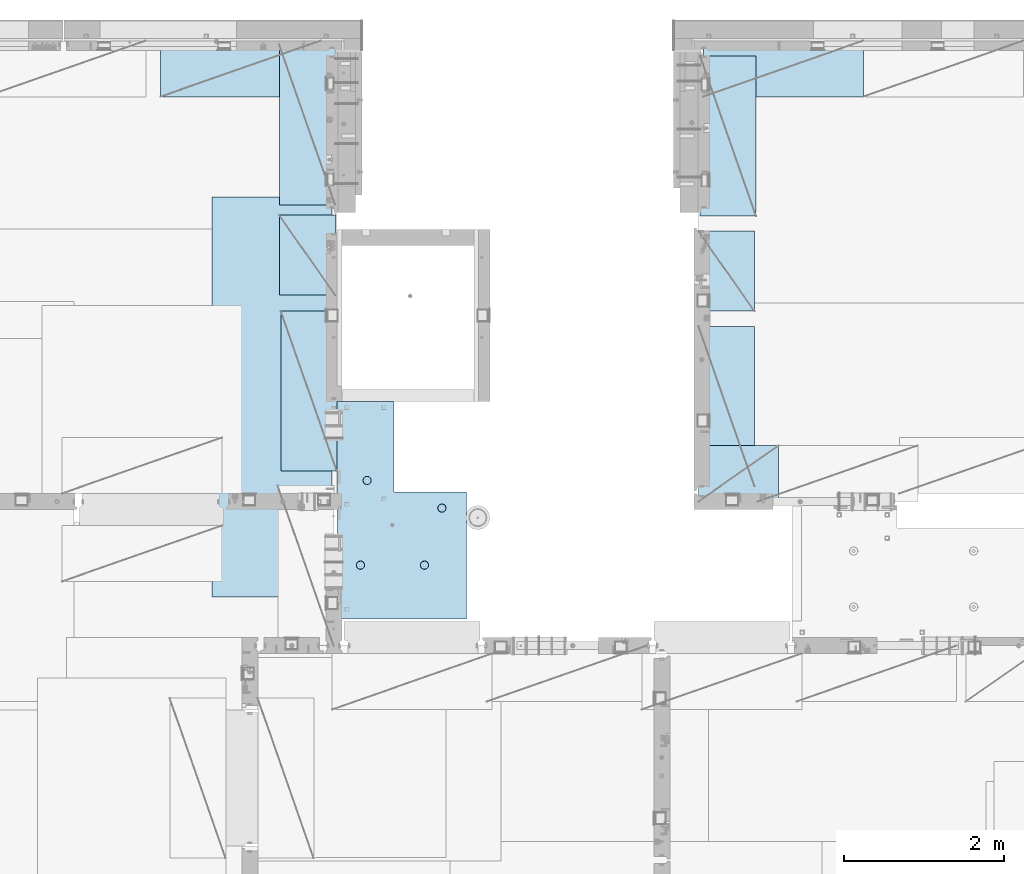
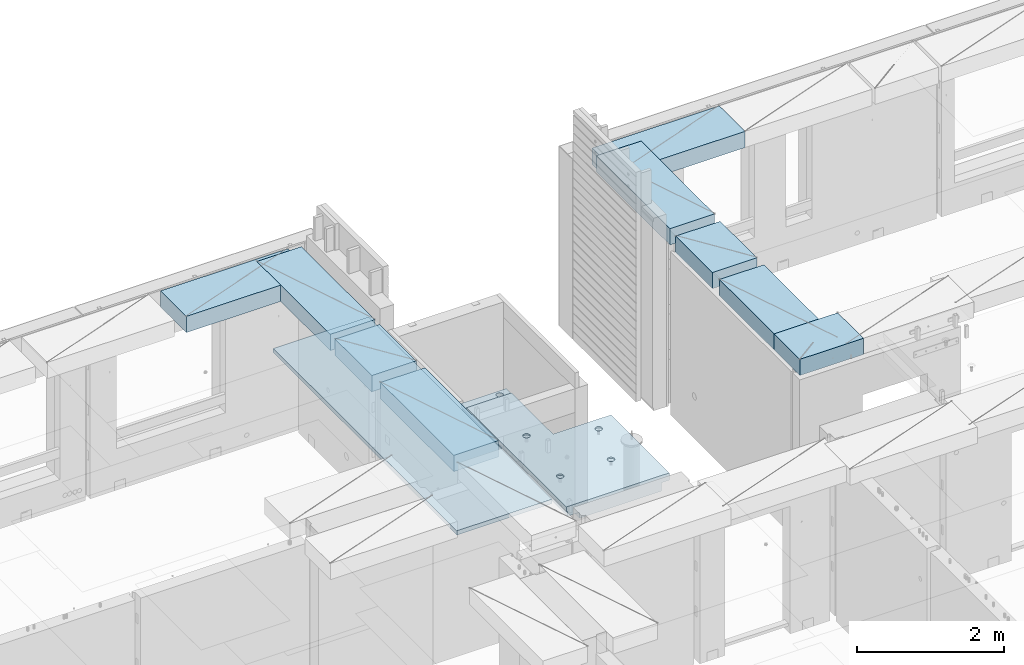
# One storey, part 177 of 309: 10 plates, 1 slab, 11 elements without a shape of their own.
"""IFC2X3 building model written with IfcOpenShell, lengths in millimetres."""

from ifc_helpers import new_model, si_unit, frame, origin_with_axes, place, context, subcontext, project, spatial, faceted_brep, material, type_object, element, aggregate, save


model = new_model("IFC2X3")

# Units and contexts
model_context = context("Model", 3, precision=1e-05, world=origin_with_axes())
body_context = subcontext(model_context, "Body", "Model", "MODEL_VIEW")
ifc_project = project(units=[si_unit("LENGTHUNIT", "METRE", prefix="MILLI"), si_unit("AREAUNIT", "SQUARE_METRE"), si_unit("VOLUMEUNIT", "CUBIC_METRE"), si_unit("MASSUNIT", "GRAM", prefix="KILO"), si_unit("TIMEUNIT", "SECOND"), si_unit("PLANEANGLEUNIT", "RADIAN"), si_unit("SOLIDANGLEUNIT", "STERADIAN"), si_unit("THERMODYNAMICTEMPERATUREUNIT", "DEGREE_CELSIUS"), si_unit("LUMINOUSINTENSITYUNIT", "LUMEN")], contexts=[model_context])

# Site, building, storey
site_placement = place(None, origin_with_axes())
site = spatial("IfcSite", under=ifc_project, at=site_placement, CompositionType="ELEMENT")
building_placement = place(site_placement, origin_with_axes())
building = spatial("IfcBuilding", under=site, at=building_placement, CompositionType="ELEMENT")
storey_placement = place(building_placement, origin_with_axes())
storey = spatial("IfcBuildingStorey", under=building, at=storey_placement, Name="7", CompositionType="ELEMENT", Elevation=0.0)

# Assembly, plate
assembly_1_placement = place(storey_placement, origin_with_axes())
assembly_1 = element("IfcElementAssembly", 1, at=assembly_1_placement, inside=storey, Name="Steel Assembly", AssemblyPlace="NOTDEFINED", PredefinedType="NOTDEFINED")
ifc_material_1 = material()
plate_type_1 = type_object("IfcPlateType", PredefinedType="NOTDEFINED")
plate_1_placement = place(assembly_1_placement, frame((17690.0000122641, 20790.0, 102695.100000381), z_axis=(0.0, -1.0, 0.0), x_axis=(-1.0, 3.00000001838171e-08, 0.0)))
plate_1 = element("IfcPlate", 2, at=plate_1_placement, type_object=plate_type_1, material=ifc_material_1, context=body_context, shape_type="Brep", body=[
    faceted_brep([(0.0, -35.0, 0.0), (0.0, -35.0, 5000.0), (0.0, 35.0, 5000.0), (0.0, 35.0, 0.0), (1499.99951171875, -35.0, 5000.0), (1499.99951171875, 35.0, 5000.0), (1500.0, -35.0, 0.0), (1500.0, 35.0, 0.0)], [[[0, 1, 2, 3]], [[1, 4, 5, 2]], [[4, 6, 7, 5]], [[6, 0, 3, 7]], [[5, 7, 3, 2]], [[6, 4, 1, 0]]]),
])
aggregate(assembly_1, [plate_1])

assembly_2_placement = place(storey_placement, origin_with_axes())
assembly_2 = element("IfcElementAssembly", 3, at=assembly_2_placement, inside=storey, Name="Steel Assembly", AssemblyPlace="NOTDEFINED", PredefinedType="NOTDEFINED")
plate_type_2 = type_object("IfcPlateType", PredefinedType="NOTDEFINED")
plate_2_placement = place(assembly_2_placement, frame((24330.0, 22740.0001220703, 102595.3), z_axis=(0.0, -1.0, 0.0), x_axis=(-1.0, 3.00000001838171e-08, 0.0)))
plate_2 = element("IfcPlate", 4, at=plate_2_placement, type_object=plate_type_2, material=ifc_material_1, Name="RE1", context=body_context, shape_type="Brep", body=[
    faceted_brep([(1.81898940354586e-12, -135.0, 1.81898940354586e-12), (0.0, -135.0, 699.999999999996), (0.0, 135.0, 699.999999999996), (1.81898940354586e-12, 135.0, 1.81898940354586e-12), (1999.99951171875, -135.0, 699.999999999993), (1999.99951171875, 135.0, 699.999999999993), (2000.0, -135.0, -3.63797880709171e-12), (2000.0, 135.0, -3.63797880709171e-12)], [[[0, 1, 2, 3]], [[1, 4, 5, 2]], [[4, 6, 7, 5]], [[6, 0, 3, 7]], [[5, 7, 3, 2]], [[6, 4, 1, 0]]]),
])
aggregate(assembly_2, [plate_2])

assembly_3_placement = place(storey_placement, origin_with_axes())
assembly_3 = element("IfcElementAssembly", 5, at=assembly_3_placement, inside=storey, Name="Steel Assembly", AssemblyPlace="NOTDEFINED", PredefinedType="NOTDEFINED")
plate_3_placement = place(assembly_3_placement, frame((17730.0001220703, 20690.0, 102595.3), z_axis=(-1.0, 3.00000001838171e-08, 0.0), x_axis=(0.0, 1.0, 0.0)))
plate_3 = element("IfcPlate", 6, at=plate_3_placement, type_object=plate_type_2, material=ifc_material_1, Name="RE1", context=body_context, shape_type="Brep", body=[
    faceted_brep([(1.81898940354586e-12, -135.0, 1.81898940354586e-12), (0.0, -135.0, 699.999999999996), (0.0, 135.0, 699.999999999996), (1.81898940354586e-12, 135.0, 1.81898940354586e-12), (1999.99951171875, -135.0, 699.999999999993), (1999.99951171875, 135.0, 699.999999999993), (2000.0, -135.0, -3.63797880709171e-12), (2000.0, 135.0, -3.63797880709171e-12)], [[[0, 1, 2, 3]], [[1, 4, 5, 2]], [[4, 6, 7, 5]], [[6, 0, 3, 7]], [[5, 7, 3, 2]], [[6, 4, 1, 0]]]),
])
aggregate(assembly_3, [plate_3])

assembly_4_placement = place(storey_placement, origin_with_axes())
assembly_4 = element("IfcElementAssembly", 7, at=assembly_4_placement, inside=storey, Name="Steel Assembly", AssemblyPlace="NOTDEFINED", PredefinedType="NOTDEFINED")
plate_4_placement = place(assembly_4_placement, frame((22269.9998779297, 19170.0, 102595.3), z_axis=(1.0, 0.0, 0.0), x_axis=(0.0, -1.0, 0.0)))
plate_4 = element("IfcPlate", 8, at=plate_4_placement, type_object=plate_type_2, material=ifc_material_1, Name="RE1", context=body_context, shape_type="Brep", body=[
    faceted_brep([(1.81898940354586e-12, -135.0, 1.81898940354586e-12), (0.0, -135.0, 699.999999999996), (0.0, 135.0, 699.999999999996), (1.81898940354586e-12, 135.0, 1.81898940354586e-12), (1999.99951171875, -135.0, 699.999999999993), (1999.99951171875, 135.0, 699.999999999993), (2000.0, -135.0, -3.63797880709171e-12), (2000.0, 135.0, -3.63797880709171e-12)], [[[0, 1, 2, 3]], [[1, 4, 5, 2]], [[4, 6, 7, 5]], [[6, 0, 3, 7]], [[5, 7, 3, 2]], [[6, 4, 1, 0]]]),
])
aggregate(assembly_4, [plate_4])

assembly_5_placement = place(storey_placement, origin_with_axes())
assembly_5 = element("IfcElementAssembly", 9, at=assembly_5_placement, inside=storey, Name="Steel Assembly", AssemblyPlace="NOTDEFINED", PredefinedType="NOTDEFINED")
plate_5_placement = place(assembly_5_placement, frame((22289.9998779297, 22550.0, 102595.3), z_axis=(1.0, 0.0, 0.0), x_axis=(0.0, -1.0, 0.0)))
plate_5 = element("IfcPlate", 10, at=plate_5_placement, type_object=plate_type_2, material=ifc_material_1, Name="RE1", context=body_context, shape_type="Brep", body=[
    faceted_brep([(1.81898940354586e-12, -135.0, 1.81898940354586e-12), (0.0, -135.0, 699.999999999996), (0.0, 135.0, 699.999999999996), (1.81898940354586e-12, 135.0, 1.81898940354586e-12), (1999.99951171875, -135.0, 699.999999999993), (1999.99951171875, 135.0, 699.999999999993), (2000.0, -135.0, -3.63797880709171e-12), (2000.0, 135.0, -3.63797880709171e-12)], [[[0, 1, 2, 3]], [[1, 4, 5, 2]], [[4, 6, 7, 5]], [[6, 0, 3, 7]], [[5, 7, 3, 2]], [[6, 4, 1, 0]]]),
])
aggregate(assembly_5, [plate_5])

assembly_6_placement = place(storey_placement, origin_with_axes())
assembly_6 = element("IfcElementAssembly", 11, at=assembly_6_placement, inside=storey, Name="Steel Assembly", AssemblyPlace="NOTDEFINED", PredefinedType="NOTDEFINED")
plate_6_placement = place(assembly_6_placement, frame((22269.9999999293, 20360.0, 102595.3), z_axis=(1.0, 0.0, 0.0), x_axis=(0.0, -1.0, 0.0)))
plate_6 = element("IfcPlate", 12, at=plate_6_placement, type_object=plate_type_2, material=ifc_material_1, Name="RE1_1/2", context=body_context, shape_type="Brep", body=[
    faceted_brep([(1.81898940354586e-12, -135.0, 1.81898940354586e-12), (0.0, -135.0, 699.999999999996), (0.0, 135.0, 699.999999999996), (1.81898940354586e-12, 135.0, 1.81898940354586e-12), (999.99951171875, -135.0, 700.0), (999.99951171875, 135.0, 700.0), (1000.0, -135.0, 0.0), (1000.0, 135.0, 0.0)], [[[0, 1, 2, 3]], [[1, 4, 5, 2]], [[4, 6, 7, 5]], [[6, 0, 3, 7]], [[5, 7, 3, 2]], [[6, 4, 1, 0]]]),
])
aggregate(assembly_6, [plate_6])

assembly_7_placement = place(storey_placement, origin_with_axes())
assembly_7 = element("IfcElementAssembly", 13, at=assembly_7_placement, inside=storey, Name="Steel Assembly", AssemblyPlace="NOTDEFINED", PredefinedType="NOTDEFINED")
plate_7_placement = place(assembly_7_placement, frame((22270.0, 16979.9999999293, 102595.3), z_axis=(0.0, 1.0, 0.0), x_axis=(1.0, 0.0, 0.0)))
plate_7 = element("IfcPlate", 14, at=plate_7_placement, type_object=plate_type_2, material=ifc_material_1, Name="RE1_1/2", context=body_context, shape_type="Brep", body=[
    faceted_brep([(1.81898940354586e-12, -135.0, 1.81898940354586e-12), (0.0, -135.0, 699.999999999996), (0.0, 135.0, 699.999999999996), (1.81898940354586e-12, 135.0, 1.81898940354586e-12), (999.99951171875, -135.0, 700.0), (999.99951171875, 135.0, 700.0), (1000.0, -135.0, 0.0), (1000.0, 135.0, 0.0)], [[[0, 1, 2, 3]], [[1, 4, 5, 2]], [[4, 6, 7, 5]], [[6, 0, 3, 7]], [[5, 7, 3, 2]], [[6, 4, 1, 0]]]),
])
aggregate(assembly_7, [plate_7])

assembly_8_placement = place(storey_placement, origin_with_axes())
assembly_8 = element("IfcElementAssembly", 15, at=assembly_8_placement, inside=storey, Name="Steel Assembly", AssemblyPlace="NOTDEFINED", PredefinedType="NOTDEFINED")
plate_8_placement = place(assembly_8_placement, frame((17750.0001220703, 17360.0, 102595.3), z_axis=(-1.0, 3.00000001838171e-08, 0.0), x_axis=(0.0, 1.0, 0.0)))
plate_8 = element("IfcPlate", 16, at=plate_8_placement, type_object=plate_type_2, material=ifc_material_1, Name="RE1", context=body_context, shape_type="Brep", body=[
    faceted_brep([(1.81898940354586e-12, -135.0, 1.81898940354586e-12), (0.0, -135.0, 699.999999999996), (0.0, 135.0, 699.999999999996), (1.81898940354586e-12, 135.0, 1.81898940354586e-12), (1999.99951171875, -135.0, 699.999999999993), (1999.99951171875, 135.0, 699.999999999993), (2000.0, -135.0, -3.63797880709171e-12), (2000.0, 135.0, -3.63797880709171e-12)], [[[0, 1, 2, 3]], [[1, 4, 5, 2]], [[4, 6, 7, 5]], [[6, 0, 3, 7]], [[5, 7, 3, 2]], [[6, 4, 1, 0]]]),
])
aggregate(assembly_8, [plate_8])

assembly_9_placement = place(storey_placement, origin_with_axes())
assembly_9 = element("IfcElementAssembly", 17, at=assembly_9_placement, inside=storey, Name="Steel Assembly", AssemblyPlace="NOTDEFINED", PredefinedType="NOTDEFINED")
plate_9_placement = place(assembly_9_placement, frame((17730.0000000707, 19560.0, 102595.3), z_axis=(-1.0, 3.00000001838171e-08, 0.0), x_axis=(0.0, 1.0, 0.0)))
plate_9 = element("IfcPlate", 18, at=plate_9_placement, type_object=plate_type_2, material=ifc_material_1, Name="RE1_1/2", context=body_context, shape_type="Brep", body=[
    faceted_brep([(1.81898940354586e-12, -135.0, 1.81898940354586e-12), (0.0, -135.0, 699.999999999996), (0.0, 135.0, 699.999999999996), (1.81898940354586e-12, 135.0, 1.81898940354586e-12), (999.99951171875, -135.0, 700.0), (999.99951171875, 135.0, 700.0), (1000.0, -135.0, 0.0), (1000.0, 135.0, 0.0)], [[[0, 1, 2, 3]], [[1, 4, 5, 2]], [[4, 6, 7, 5]], [[6, 0, 3, 7]], [[5, 7, 3, 2]], [[6, 4, 1, 0]]]),
])
aggregate(assembly_9, [plate_9])

assembly_10_placement = place(storey_placement, origin_with_axes())
assembly_10 = element("IfcElementAssembly", 19, at=assembly_10_placement, inside=storey, Name="Steel Assembly", AssemblyPlace="NOTDEFINED", PredefinedType="NOTDEFINED")
plate_10_placement = place(assembly_10_placement, frame((17545.0, 22740.0001220703, 102595.3), z_axis=(0.0, -1.0, 0.0), x_axis=(-1.0, 3.00000001838171e-08, 0.0)))
plate_10 = element("IfcPlate", 20, at=plate_10_placement, type_object=plate_type_2, material=ifc_material_1, Name="RE1", context=body_context, shape_type="Brep", body=[
    faceted_brep([(1.81898940354586e-12, -135.0, 1.81898940354586e-12), (0.0, -135.0, 699.999999999996), (0.0, 135.0, 699.999999999996), (1.81898940354586e-12, 135.0, 1.81898940354586e-12), (1999.99951171875, -135.0, 699.999999999993), (1999.99951171875, 135.0, 699.999999999993), (2000.0, -135.0, -3.63797880709171e-12), (2000.0, 135.0, -3.63797880709171e-12)], [[[0, 1, 2, 3]], [[1, 4, 5, 2]], [[4, 6, 7, 5]], [[6, 0, 3, 7]], [[5, 7, 3, 2]], [[6, 4, 1, 0]]]),
])
aggregate(assembly_10, [plate_10])

# Assembly, slab
assembly_11_placement = place(storey_placement, origin_with_axes())
assembly_11 = element("IfcElementAssembly", 21, at=assembly_11_placement, inside=storey, AssemblyPlace="NOTDEFINED", PredefinedType="REINFORCEMENT_UNIT")
ifc_material_2 = material(Name="CONCRETE/C25/30")
slab_type = type_object("IfcSlabType", PredefinedType="NOTDEFINED")
slab_placement = place(assembly_11_placement, frame((19370.0122708302, 15509.9992031236, 102620.0), z_axis=(-0.999999999999509, -9.91000000794397e-07, 0.0), x_axis=(-1.19799915409591e-06, 0.999999999999282, 0.0)))
slab = element("IfcSlab", 22, at=slab_placement, type_object=slab_type, material=ifc_material_2, PredefinedType="FLOOR", context=body_context, shape_type="Brep", body=[
    faceted_brep([(1404.48920833377, -110.0, 261.536838863547), (1418.42762122965, -110.0, 268.638814959551), (1429.48920833377, -110.0, 279.700402063678), (1436.59118442978, -110.0, 293.638814959559), (1439.03835861502, -110.0, 309.0896646783), (1436.59118442978, -110.0, 324.540514397049), (1429.48920833377, -110.0, 338.478927292927), (1418.42762122965, -110.0, 349.540514397049), (1404.48920833377, -110.0, 356.642490493057), (1389.03835861502, -110.0, 359.089664678304), (1373.58750889627, -110.0, 356.642490493057), (1359.6490960004, -110.0, 349.540514397053), (1348.58750889628, -110.0, 338.478927292927), (1341.48553280027, -110.0, 324.540514397046), (1339.03835861502, -110.0, 309.0896646783), (1341.48553280027, -110.0, 293.638814959555), (1348.58750889627, -110.0, 279.700402063678), (1359.6490960004, -110.0, 268.638814959555), (1373.58750889628, -110.0, 261.536838863547), (1389.03835861502, -110.0, 259.0896646783), (1419.76349680304, -130.0, 266.800139972343), (1405.19151968462, -130.0, 259.375346781057), (1431.32788332099, -130.0, 278.364526490292), (1438.75267651227, -130.0, 292.936503608704), (1441.31108588776, -130.0, 309.0896646783), (1438.75267651227, -130.0, 325.242825747901), (1431.32788332098, -130.0, 339.81480286632), (1419.76349680304, -130.0, 351.379189384264), (1405.19151968462, -130.0, 358.803982575551), (1389.03835861502, -130.0, 361.362391951032), (1372.88519754542, -130.0, 358.803982575548), (1358.313220427, -130.0, 351.379189384261), (1346.74883390906, -130.0, 339.814802866313), (1339.32404071778, -130.0, 325.242825747901), (1336.76563134229, -130.0, 309.0896646783), (1339.32404071778, -130.0, 292.936503608704), (1346.74883390906, -130.0, 278.364526490284), (1358.31322042701, -130.0, 266.80013997234), (1372.88519754542, -130.0, 259.375346781053), (1389.03835861502, -130.0, 256.816937405572), (691.130427682641, -110.0, 1279.3576934681), (705.068840578519, -110.0, 1286.4596695641), (716.130427682641, -110.0, 1297.52125666823), (723.232403778651, -110.0, 1311.45966956411), (725.679577963894, -110.0, 1326.91051928285), (723.232403778651, -110.0, 1342.3613690016), (716.130427682639, -110.0, 1356.29978189748), (705.068840578519, -110.0, 1367.3613690016), (691.130427682641, -110.0, 1374.46334509761), (675.679577963894, -110.0, 1376.91051928285), (660.228728245147, -110.0, 1374.46334509761), (646.29031534927, -110.0, 1367.3613690016), (635.228728245147, -110.0, 1356.29978189748), (628.126752149135, -110.0, 1342.3613690016), (625.679577963894, -110.0, 1326.91051928285), (628.126752149135, -110.0, 1311.4596695641), (635.228728245147, -110.0, 1297.52125666823), (646.290315349272, -110.0, 1286.45966956411), (660.228728245147, -110.0, 1279.35769346809), (675.679577963894, -110.0, 1276.91051928285), (691.832739033494, -130.0, 1277.19620138561), (675.679577963892, -130.0, 1274.63779201012), (706.404716151908, -130.0, 1284.62099457689), (717.969102669858, -130.0, 1296.18538109484), (725.393895861142, -130.0, 1310.75735821325), (727.952305236622, -130.0, 1326.91051928285), (725.393895861142, -130.0, 1343.06368035245), (717.96910266986, -130.0, 1357.63565747087), (706.40471615191, -130.0, 1369.20004398881), (691.832739033493, -130.0, 1376.6248371801), (675.679577963894, -130.0, 1379.18324655558), (659.526416894296, -130.0, 1376.6248371801), (644.954439775878, -130.0, 1369.20004398881), (633.390053257932, -130.0, 1357.63565747087), (625.965260066649, -130.0, 1343.06368035245), (623.406850691168, -130.0, 1326.91051928285), (625.965260066647, -130.0, 1310.75735821325), (633.39005325793, -130.0, 1296.18538109483), (644.954439775878, -130.0, 1284.62099457689), (659.526416894296, -130.0, 1277.1962013856), (1390.00354003907, -130.0, -1.24055077321827e-09), (1390.00354003907, -10.0000000000582, -1.20780896395445e-09), (1390.48503205676, -10.0000000000582, 2.00184877030551e-06), (1390.48503205676, 130.0, 2.00184877030551e-06), (1590.48701548117, 130.0, 0.000834030026453547), (1590.48701548117, -130.0, 0.000834030026453547), (1390.48499929675, 129.999999999942, 120.000071381241), (1390.48499929675, -10.0000000000582, 120.000071381241), (0.00020267313993827, -10.0000000000582, 119.999691808891), (0.000202673141757259, 130.0, 119.999691808891), (0.0, -10.0, 0.0), (0.0, -130.0, -3.63797880709171e-12), (2869.99538844816, 50.0011266965448, 1600.01611050633), (2869.99536132813, 50.0011350165441, 1620.01123046875), (2149.99371079323, 50.0010478963522, 1620.01135296499), (2149.99368684219, 50.0010410163377, 1600.01617458649), (2149.99368684219, 30.0, 1600.01617458649), (2149.99345921271, 30.0, 1410.00825692148), (1649.99345921307, 30.0, 1410.00885592148), (1649.99368684195, 30.0, 1600.01626486659), (1649.99368684189, 50.0009815163357, 1600.01621908649), (1649.99371079351, 50.0009873963572, 1620.01143803163), (700.003710793628, 50.0008724475629, 1620.01159965654), (700.003686840937, 50.0008724475629, 1600.01632471597), (0.00270234311210515, 30.0, 1600.01636881603), (700.003686840937, 30.0, 1600.01632471597), (700.003459213352, 30.0, 1410.0099940095), (0.0034592138545122, 30.0, 1410.0108326095), (0.00270234311210515, -49.9992122525582, 1600.01636881602), (2869.99538844816, -49.9988733034552, 1600.01611050632), (2869.99536132813, 130.0, 1620.01123046875), (2869.99536132813, -49.9988649834559, 1620.01123046875), (2869.99536132813, -109.999999999985, 1620.01123046875), (2869.99632432729, -110.000000000058, 910.008986653265), (2869.99632432729, 130.0, 910.008986653265), (2149.99371079323, 130.0, 1620.01135296499), (2149.99345921271, 130.0, 1410.00825692148), (1649.99345921307, 130.0, 1410.00885592148), (1649.99371079351, 130.0, 1620.01143803163), (700.003710793628, 130.0, 1620.01159965654), (700.003459213352, 130.0, 1410.0099940095), (0.00238143379829125, 130.0, 1410.01083261132), (0.00273612328055606, -130.0, 1620.01171875), (0.00273611420016096, -49.9992122525582, 1620.01171875), (2719.99530409285, -130.0, 1620.01125598875), (2719.99530409285, -110.000000000058, 1620.01125598875), (2719.99625549565, -130.0, 910.009166353349), (2719.99625549565, -110.000000000058, 910.009166353349), (2755.60764453383, -110.000000000058, 1019.55932468986), (2744.5460706815, -110.000000000058, 1030.62092504577), (2737.44411128371, -110.000000000058, 1044.5593464498), (2734.99695560859, -110.000000000058, 1060.01019910025), (2737.44414830394, -110.000000000058, 1075.46104588727), (2744.54614109817, -110.000000000058, 1089.39945027497), (2755.60774145406, -110.000000000058, 1100.4610241273), (2769.5461628581, -110.000000000058, 1107.56298352509), (2784.99701550855, -110.000000000058, 1110.01013920022), (2800.44786229558, -110.000000000058, 1107.56294650486), (2814.38626668327, -110.000000000058, 1100.46095371063), (2825.44784053561, -110.000000000058, 1089.39935335474), (2832.54979993339, -110.000000000058, 1075.4609319507), (2834.99695560852, -110.000000000058, 1060.01007930025), (2832.54976291315, -110.000000000058, 1044.55923251323), (2825.44777011894, -110.000000000058, 1030.62082812553), (2814.38616976303, -110.000000000058, 1019.55925427319), (2800.44774835901, -110.000000000058, 1012.45729487541), (2784.99689570855, -110.000000000058, 1010.01013920029), (2769.54604892153, -110.000000000058, 1012.45733189565), (2814.38616976303, 130.000000000015, 1019.55925427319), (2800.44774835901, 130.000000000015, 1012.45729487541), (2825.44777011894, 130.000000000015, 1030.62082812553), (2832.54976291315, 130.000000000015, 1044.55923251323), (2834.99695560852, 130.000000000015, 1060.01007930025), (2832.54979993339, 130.000000000015, 1075.4609319507), (2825.44784053561, 130.000000000015, 1089.39935335474), (2814.38626668327, 130.000000000015, 1100.46095371063), (2800.44786229558, 130.000000000015, 1107.56294650486), (2784.99701550855, 130.000000000015, 1110.01013920022), (2769.5461628581, 130.000000000015, 1107.56298352509), (2755.60774145406, 130.000000000015, 1100.4610241273), (2744.54614109817, 130.000000000015, 1089.39945027497), (2737.44414830394, 130.000000000015, 1075.46104588727), (2734.99695560859, 130.000000000015, 1060.01019910025), (2737.44411128371, 130.000000000015, 1044.5593464498), (2744.5460706815, 130.000000000015, 1030.62092504577), (2755.60764453383, 130.000000000015, 1019.55932468986), (2769.54604892153, 130.000000000015, 1012.45733189565), (2784.99689570855, 130.000000000015, 1010.01013920029), (1590.48810567277, 130.0, 910.010519504111), (1590.48810567277, -130.0, 910.010519504111), (1750.45032808017, -110.0, 1196.2164244028), (1764.38874097604, -110.0, 1203.3184004988), (1775.45032808016, -110.0, 1214.37998760293), (1782.55230417617, -110.0, 1228.31840049881), (1784.99947836141, -110.0, 1243.76925021755), (1782.55230417617, -110.0, 1259.2200999363), (1775.45032808016, -110.0, 1273.15851283217), (1764.38874097604, -110.0, 1284.2200999363), (1750.45032808016, -110.0, 1291.32207603231), (1734.99947836141, -110.0, 1293.76925021755), (1719.54862864267, -110.0, 1291.32207603231), (1705.61021574679, -110.0, 1284.2200999363), (1694.54862864267, -110.0, 1273.15851283217), (1687.44665254666, -110.0, 1259.2200999363), (1684.99947836142, -110.0, 1243.76925021755), (1687.44665254666, -110.0, 1228.3184004988), (1694.54862864267, -110.0, 1214.37998760293), (1705.61021574679, -110.0, 1203.31840049881), (1719.54862864267, -110.0, 1196.2164244028), (1734.99947836142, -110.0, 1193.76925021755), (1751.15263943101, -130.0, 1194.05493232031), (1734.99947836141, -130.0, 1191.49652294482), (1765.72461654943, -130.0, 1201.47972551159), (1777.28900306738, -130.0, 1213.04411202954), (1784.71379625866, -130.000000000015, 1227.61608914795), (1787.27220563414, -130.000000000015, 1243.76925021755), (1784.71379625866, -130.000000000015, 1259.92241128715), (1777.28900306738, -130.000000000015, 1274.49438840557), (1765.72461654943, -130.000000000015, 1286.05877492352), (1751.15263943101, -130.000000000015, 1293.4835681148), (1734.99947836142, -130.000000000015, 1296.04197749028), (1718.84631729182, -130.000000000015, 1293.4835681148), (1704.2743401734, -130.000000000015, 1286.05877492352), (1692.70995365545, -130.000000000015, 1274.49438840556), (1685.28516046416, -130.000000000015, 1259.92241128715), (1682.72675108869, -130.000000000015, 1243.76925021755), (1685.28516046417, -130.000000000015, 1227.61608914795), (1692.70995365545, -130.0, 1213.04411202953), (1704.2743401734, -130.0, 1201.47972551159), (1718.84631729182, -130.0, 1194.0549323203), (691.129469282641, -110.0, 479.357693468672), (705.067882178519, -110.0, 486.459669564676), (716.129469282641, -110.0, 497.521256668799), (723.231445378651, -110.0, 511.459669564683), (725.678619563894, -110.0, 526.910519283429), (723.231445378651, -110.0, 542.361369002174), (716.12946928264, -110.0, 556.299781898051), (705.067882178519, -110.0, 567.361369002174), (691.129469282641, -110.0, 574.463345098182), (675.678619563894, -110.0, 576.910519283425), (660.227769845147, -110.0, 574.463345098182), (646.28935694927, -110.0, 567.361369002178), (635.227769845147, -110.0, 556.299781898051), (628.125793749135, -110.0, 542.36136900217), (625.678619563894, -110.0, 526.910519283425), (628.125793749135, -110.0, 511.45966956468), (635.227769845147, -110.0, 497.521256668802), (646.289356949272, -110.0, 486.45966956468), (660.227769845147, -110.0, 479.357693468668), (675.678619563894, -110.0, 476.910519283425), (691.831780633494, -130.0, 477.196201386181), (675.678619563892, -130.0, 474.637792010697), (706.403757751908, -130.0, 484.620994577464), (717.968144269858, -130.0, 496.185381095413), (725.392937461142, -130.0, 510.757358213828), (727.951346836622, -130.0, 526.910519283429), (725.392937461142, -130.0, 543.063680353025), (717.96814426986, -130.0, 557.635657471445), (706.40375775191, -130.0, 569.200043989389), (691.831780633493, -130.0, 576.624837180676), (675.678619563894, -130.0, 579.183246556153), (659.525458494296, -130.0, 576.624837180672), (644.953481375878, -130.0, 569.200043989385), (633.389094857932, -130.0, 557.635657471437), (625.964301666649, -130.0, 543.063680353025), (623.405892291168, -130.0, 526.910519283429), (625.964301666647, -130.0, 510.757358213828), (633.38909485793, -130.0, 496.185381095409), (644.953481375878, -130.0, 484.620994577464), (659.525458494296, -130.0, 477.196201386174)], [[[0, 1, 2, 3, 4, 5, 6, 7, 8, 9, 10, 11, 12, 13, 14, 15, 16, 17, 18, 19]], [[20, 1, 0, 21]], [[22, 2, 1, 20]], [[23, 3, 2, 22]], [[24, 4, 3, 23]], [[25, 5, 4, 24]], [[26, 6, 5, 25]], [[27, 7, 6, 26]], [[28, 8, 7, 27]], [[29, 9, 8, 28]], [[30, 10, 9, 29]], [[31, 11, 10, 30]], [[32, 12, 11, 31]], [[33, 13, 12, 32]], [[34, 14, 13, 33]], [[35, 15, 14, 34]], [[36, 16, 15, 35]], [[37, 17, 16, 36]], [[38, 18, 17, 37]], [[39, 19, 18, 38]], [[21, 0, 19, 39]], [[40, 41, 42, 43, 44, 45, 46, 47, 48, 49, 50, 51, 52, 53, 54, 55, 56, 57, 58, 59]], [[60, 40, 59, 61]], [[62, 41, 40, 60]], [[63, 42, 41, 62]], [[64, 43, 42, 63]], [[65, 44, 43, 64]], [[66, 45, 44, 65]], [[67, 46, 45, 66]], [[68, 47, 46, 67]], [[69, 48, 47, 68]], [[70, 49, 48, 69]], [[71, 50, 49, 70]], [[72, 51, 50, 71]], [[73, 52, 51, 72]], [[74, 53, 52, 73]], [[75, 54, 53, 74]], [[76, 55, 54, 75]], [[77, 56, 55, 76]], [[78, 57, 56, 77]], [[79, 58, 57, 78]], [[61, 59, 58, 79]], [[80, 81, 82, 83, 84, 85]], [[86, 87, 88, 89]], [[82, 87, 86, 83]], [[81, 90, 88, 87, 82]], [[80, 91, 90, 81]], [[92, 93, 94, 95]], [[96, 97, 98, 99]], [[100, 101, 102, 103]], [[104, 105, 106, 107]], [[108, 109, 92, 95, 96, 99, 100, 103, 105, 104]], [[110, 93, 92, 109, 111, 112, 113, 114]], [[93, 110, 115, 94]], [[116, 97, 96, 95, 94, 115]], [[117, 98, 97, 116]], [[118, 101, 100, 99, 98, 117]], [[101, 118, 119, 102]], [[120, 106, 105, 103, 102, 119]], [[121, 107, 106, 120]], [[89, 88, 90, 91, 122, 123, 108, 104, 107, 121]], [[109, 108, 123, 111]], [[122, 124, 125, 112, 111, 123]], [[125, 124, 126, 127]], [[112, 125, 127, 113], [128, 129, 130, 131, 132, 133, 134, 135, 136, 137, 138, 139, 140, 141, 142, 143, 144, 145, 146, 147]], [[144, 148, 149, 145]], [[143, 150, 148, 144]], [[142, 151, 150, 143]], [[141, 152, 151, 142]], [[140, 153, 152, 141]], [[139, 154, 153, 140]], [[138, 155, 154, 139]], [[137, 156, 155, 138]], [[136, 157, 156, 137]], [[135, 158, 157, 136]], [[134, 159, 158, 135]], [[133, 160, 159, 134]], [[132, 161, 160, 133]], [[131, 162, 161, 132]], [[130, 163, 162, 131]], [[129, 164, 163, 130]], [[128, 165, 164, 129]], [[147, 166, 165, 128]], [[146, 167, 166, 147]], [[145, 149, 167, 146]], [[118, 117, 116, 115, 110, 114, 168, 84, 83, 86, 89, 121, 120, 119], [148, 150, 151, 152, 153, 154, 155, 156, 157, 158, 159, 160, 161, 162, 163, 164, 165, 166, 167, 149]], [[113, 127, 126, 169, 168, 114]], [[85, 84, 168, 169]], [[170, 171, 172, 173, 174, 175, 176, 177, 178, 179, 180, 181, 182, 183, 184, 185, 186, 187, 188, 189]], [[190, 170, 189, 191]], [[192, 171, 170, 190]], [[193, 172, 171, 192]], [[194, 173, 172, 193]], [[195, 174, 173, 194]], [[196, 175, 174, 195]], [[197, 176, 175, 196]], [[198, 177, 176, 197]], [[199, 178, 177, 198]], [[200, 179, 178, 199]], [[201, 180, 179, 200]], [[202, 181, 180, 201]], [[203, 182, 181, 202]], [[204, 183, 182, 203]], [[205, 184, 183, 204]], [[206, 185, 184, 205]], [[207, 186, 185, 206]], [[208, 187, 186, 207]], [[209, 188, 187, 208]], [[191, 189, 188, 209]], [[210, 211, 212, 213, 214, 215, 216, 217, 218, 219, 220, 221, 222, 223, 224, 225, 226, 227, 228, 229]], [[230, 210, 229, 231]], [[232, 211, 210, 230]], [[233, 212, 211, 232]], [[234, 213, 212, 233]], [[235, 214, 213, 234]], [[236, 215, 214, 235]], [[237, 216, 215, 236]], [[238, 217, 216, 237]], [[239, 218, 217, 238]], [[240, 219, 218, 239]], [[241, 220, 219, 240]], [[242, 221, 220, 241]], [[243, 222, 221, 242]], [[244, 223, 222, 243]], [[245, 224, 223, 244]], [[246, 225, 224, 245]], [[247, 226, 225, 246]], [[248, 227, 226, 247]], [[249, 228, 227, 248]], [[231, 229, 228, 249]], [[126, 124, 122, 91, 80, 85, 169], [37, 36, 35, 34, 33, 32, 31, 30, 29, 28, 27, 26, 25, 24, 23, 22, 20, 21, 39, 38], [248, 247, 246, 245, 244, 243, 242, 241, 240, 239, 238, 237, 236, 235, 234, 233, 232, 230, 231, 249], [208, 207, 206, 205, 204, 203, 202, 201, 200, 199, 198, 197, 196, 195, 194, 193, 192, 190, 191, 209], [78, 77, 76, 75, 74, 73, 72, 71, 70, 69, 68, 67, 66, 65, 64, 63, 62, 60, 61, 79]]]),
])
aggregate(assembly_11, [slab])

save(model, "model.ifc")
